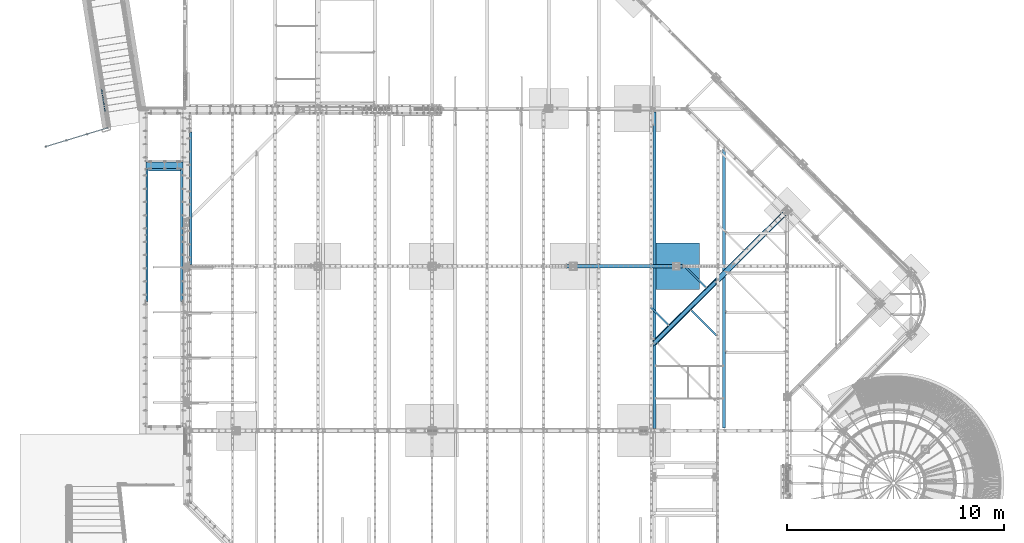
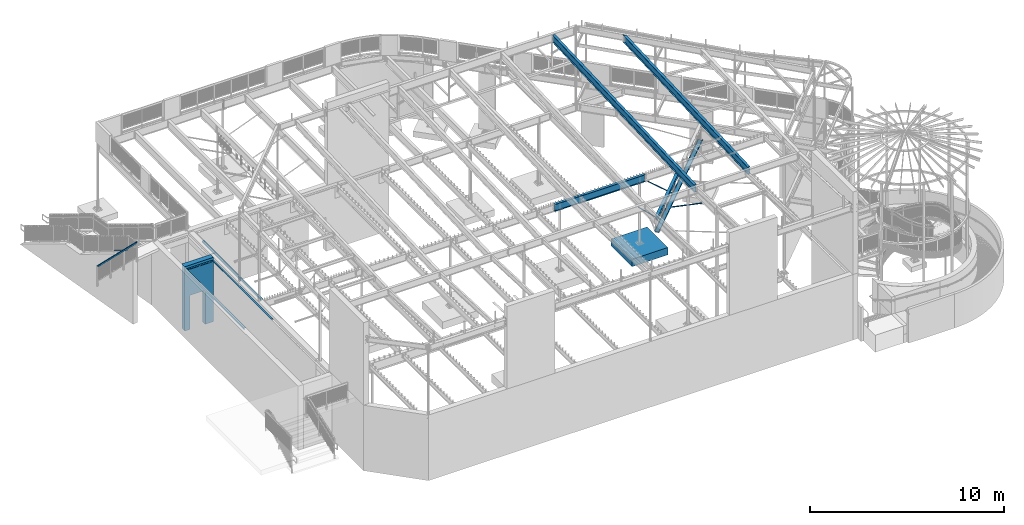
# One storey, part 318 of 975: 15 beams, 1 member.
"""IFC2X3 building model written with IfcOpenShell, lengths in millimetres."""

from ifc_helpers import new_model, si_unit, frame, origin_with_axes, place, context, subcontext, project, spatial, faceted_brep, material, type_object, element, save


model = new_model("IFC2X3")

# Units and contexts
model_context = context("Model", 3, precision=1e-05, world=origin_with_axes())
body_context = subcontext(model_context, "Body", "Model", "MODEL_VIEW")
ifc_project = project(units=[si_unit("LENGTHUNIT", "METRE", prefix="MILLI"), si_unit("AREAUNIT", "SQUARE_METRE"), si_unit("VOLUMEUNIT", "CUBIC_METRE"), si_unit("MASSUNIT", "GRAM", prefix="KILO"), si_unit("TIMEUNIT", "SECOND"), si_unit("PLANEANGLEUNIT", "RADIAN"), si_unit("SOLIDANGLEUNIT", "STERADIAN"), si_unit("THERMODYNAMICTEMPERATUREUNIT", "DEGREE_CELSIUS"), si_unit("LUMINOUSINTENSITYUNIT", "LUMEN")], contexts=[model_context])

# Site, building, storey
site_placement = place(None, origin_with_axes())
site = spatial("IfcSite", under=ifc_project, at=site_placement, CompositionType="ELEMENT")
building_placement = place(site_placement, origin_with_axes())
building = spatial("IfcBuilding", under=site, at=building_placement, Name="Undefined", CompositionType="ELEMENT")
storey_placement = place(building_placement, origin_with_axes())
storey = spatial("IfcBuildingStorey", under=building, at=storey_placement, Name="Undefined", CompositionType="ELEMENT", Elevation=0.0)

# Beams
ifc_material_1 = material(Name="STEEL/A36")
beam_type_1 = type_object("IfcBeamType", Name="L3X3X3/16", PredefinedType="NOTDEFINED")
beam_1_placement = place(storey_placement, frame((23532.3947969943, 11528.9190808216, 3502.75524173699), z_axis=(-0.709247305908776, -0.704959757050815, -4.93100742460229e-11), x_axis=(0.632701534936731, -0.636549610936345, -0.441014013955898)))
element("IfcBeam", 1, at=beam_1_placement, inside=storey, type_object=beam_type_1, material=ifc_material_1, Name="ANGLE", ObjectType="L3X3X3/16", context=body_context, shape_type="Brep", body=[
    faceted_brep([(1300.11028612074, -38.0999926474587, -33.3375000002998), (1300.11028612073, -38.0999919468331, -38.1000000003223), (1300.11028576719, 33.3375071467353, -38.1000000003878), (1300.11028575761, 33.3375071517066, -33.3375000008564), (1328.20676165132, -23.8411616900694, -38.1000000004606), (1328.20676259087, -23.8411612278051, -33.337500000016), (1332.4811051317, -21.7408313065953, 38.1000000000422), (1328.20676258711, -23.8411612207919, 38.1000000000276), (1332.48110667282, -21.7408305587751, -38.1000000000058), (29.8255381832114, -38.0999998359339, -33.337500000096), (29.8255381837498, -38.0999998359357, -38.1000000001004), (1255.61719203559, -38.0999930930348, -38.1000000009262), (1255.61719203553, -38.0999930930348, -33.3375000009219), (29.8255378065924, 38.1000001640541, -38.0999999999949), (29.8255378296262, 33.3375001640552, -33.3374999999978), (29.8255378215326, 33.3375001640679, 38.1000000000458), (29.8255377979613, 38.1000001640668, 38.1000000000495), (1303.07649200474, 38.1000071680346, 38.0999999991909), (1303.07649200582, 38.1000071680219, -38.1000000008607), (1300.1102857566, 33.3375071517194, 38.0999999991873)], [[[0, 1, 2, 3]], [[3, 2, 4, 5]], [[6, 7, 5, 4, 8]], [[9, 10, 11, 12]], [[13, 10, 9, 14, 15, 16]], [[13, 16, 17, 18]], [[18, 17, 6, 8]], [[2, 1, 11, 10, 13, 18, 8, 4]], [[12, 11, 1, 0]], [[14, 9, 12, 0, 3]], [[15, 14, 3, 19]], [[19, 3, 5, 7]], [[17, 16, 15, 19, 7, 6]]]),
])
beam_2_placement = place(storey_placement, frame((25439.2732581106, 11339.9529433271, 2870.2), z_axis=(-0.709199630836852, -0.705007718837796, 0.0), x_axis=(0.0, 0.0, 1.0)))
element("IfcBeam", 2, at=beam_2_placement, inside=storey, type_object=beam_type_1, material=ifc_material_1, Name="ANGLE", ObjectType="L3X3X3/16", context=body_context, shape_type="Brep", body=[
    faceted_brep([(25.4024092950699, 33.3375000220076, 38.0996831838311), (25.4024106305014, 38.1000000220156, 38.0996831838165), (25.4024106075244, 38.1000000220774, -38.1003168220304), (25.4024092720929, 33.3373553605707, -38.1003168220159), (25.402409273529, 33.3375000220658, -33.337816821655), (88.6495798217943, 33.3374797291181, -33.3386056411655), (88.6493538730001, 33.3374980933804, -38.1011056385905), (20.9337944619647, 10.5729718175626, -38.1002610894247), (20.9336505701117, 10.5730674953247, -33.3377610872667), (92.0727332259908, 38.1000000797758, -38.1011483350085), (92.0772756973574, 38.1000000797139, 38.0988516141842), (109.689939138608, -14.2966740807897, 38.096898254993), (109.687479406867, -14.2921842647538, -38.1031015729495), (651.166944553913, -1624.99578907391, 37.9845146471816), (651.164484834565, -1624.99129929474, -38.2154851807682), (37.298686389729, -38.0999999677424, -38.1004651925723), (88.6538977700911, 33.3375000767483, 38.0988943105876), (105.173392271, -15.8100404521865, -33.340545282048), (105.175698269507, -15.8142496547207, 38.0969545566513), (37.2989702941895, -38.0999999677442, -33.3379651957475), (37.4597792344907, -38.5736740610846, -33.3397007571657), (36.7987457864328, -36.61339332444, -33.3379589569413), (37.4596255012571, -38.5733934475829, -38.1022007464089), (578.936630933475, -1649.27250849101, -38.2145843542203), (578.936784665934, -1649.27278910221, -33.4520843649771), (646.650397698207, -1626.50915548071, -33.4529288898593), (646.652703685095, -1626.51336464868, 37.9845709488436)], [[[0, 1, 2, 3, 4]], [[5, 6, 7, 8]], [[4, 3, 6, 5]], [[9, 10, 11, 12]], [[12, 11, 13, 14]], [[15, 7, 6]], [[16, 5, 17, 18]], [[5, 19, 20, 17]], [[21, 19, 5, 8]], [[15, 19, 21, 8, 7]], [[20, 19, 15, 22, 23, 24]], [[17, 20, 24, 25]], [[18, 17, 25, 26]], [[11, 18, 26, 13]], [[25, 24, 23, 14, 13, 26]], [[22, 12, 14, 23]], [[15, 6, 9, 12, 22]], [[2, 9, 6, 3]], [[10, 9, 2, 1]], [[16, 18, 11, 10, 1, 0]], [[5, 16, 0, 4]]]),
])
beam_3_placement = place(storey_placement, frame((25135.3295319196, 13375.0116337592, 3450.62546657707), z_axis=(-0.709179074487965, -0.705028396809939, -8.76857484399806e-11), x_axis=(0.657370205901574, -0.661240307900995, -0.361421730945886)))
element("IfcBeam", 3, at=beam_3_placement, inside=storey, type_object=beam_type_1, material=ifc_material_1, Name="ANGLE", ObjectType="L3X3X3/16", context=body_context, shape_type="Brep", body=[
    faceted_brep([(1446.22221908493, -38.1000412902176, -33.3375000004489), (1446.22234837766, -38.1000092563336, -38.1000000004569), (1446.22234884808, 33.3375413504145, -38.1000000005261), (1446.22221952836, 33.337491228931, -33.3375000006599), (1469.14322783126, -25.7884124715474, -38.1000000005297), (1469.14115987072, -25.7892140619915, -33.3375000003944), (1473.55211840428, -24.0794174486964, 38.0999990750715), (1469.14115986524, -25.7892140483646, 38.0999999996202), (1473.58172572751, -24.0679409512677, -38.1000000003878), (40.491462140827, -38.1000002455685, -33.3375000000196), (40.4915914333369, -38.1000002455667, -38.100000000024), (1397.29652750821, -38.1000084743628, -38.1000000006425), (1397.29652750818, -38.1000084743655, -33.3375000006417), (40.4915919351606, 38.0999997544568, -38.1000000000204), (40.491462611285, 33.3374997544524, -33.3375000000233), (40.4895232236322, 33.3374997544306, 38.0999999999876), (40.489523254997, 38.0999997544313, 38.0999999999913), (1449.4839323293, 38.0999912091138, 38.0999999993437), (1449.48393232973, 38.099991209152, -38.1000000006643), (1446.22221952795, 33.3374912288946, 38.0999999993473)], [[[0, 1, 2, 3]], [[3, 2, 4, 5]], [[6, 7, 5, 4, 8]], [[9, 10, 11, 12]], [[13, 10, 9, 14, 15, 16]], [[13, 16, 17, 18]], [[18, 17, 6, 8]], [[2, 1, 11, 10, 13, 18, 8, 4]], [[12, 11, 1, 0]], [[14, 9, 12, 0, 3]], [[15, 14, 3, 19]], [[19, 3, 5, 7]], [[17, 16, 15, 19, 7, 6]]]),
])
beam_type_2 = type_object("IfcBeamType", Name="C10X15.3", PredefinedType="NOTDEFINED")
beam_4_placement = place(storey_placement, frame((23709.1622039582, 9853.15276556714, 2928.9375), z_axis=(-0.705001493913394, 0.709205818912876, 0.0), x_axis=(0.709205818912877, 0.705001493913393, 0.0)))
element("IfcBeam", 4, at=beam_4_placement, inside=storey, type_object=beam_type_2, material=ifc_material_1, Name="BEAM", ObjectType="C10X15.3", context=body_context, shape_type="Brep", body=[
    faceted_brep([(-1.70985003933311e-10, 33.3375000000001, -126.999999999975), (1.78260961547494e-10, 33.3375000000001, 126.999999999975), (8561.77582131003, 33.3375000000001, 127.000000010328), (8561.77582130969, 33.3375000000001, -126.999999989615), (1.78260961547494e-10, -33.3375000000001, 126.999999999975), (8561.77582131003, -33.3375000000001, 127.000000010328), (1.70985003933311e-10, -33.3375000000001, 121.441527499974), (8561.77582131002, -33.3375000000001, 121.441527510331), (1.52795109897852e-10, 26.9875000000002, 111.391382499978), (8561.77582131001, 26.9875000000002, 111.391382510332), (-1.4915713109076e-10, 26.9875000000002, -111.391382499976), (8561.7758213097, 26.9875000000002, -111.391382489623), (-1.63709046319127e-10, -33.3375000000001, -121.44152749997), (8561.77582130969, -33.3375000000001, -121.44152748962), (-1.70985003933311e-10, -33.3375000000001, -126.999999999975), (8561.77582130969, -33.3375000000001, -126.999999989615)], [[[0, 1, 2, 3]], [[1, 4, 5, 2]], [[4, 6, 7, 5]], [[6, 8, 9, 7]], [[8, 10, 11, 9]], [[10, 12, 13, 11]], [[12, 14, 15, 13]], [[14, 0, 3, 15]], [[5, 7, 9, 11, 13, 15, 3, 2]], [[14, 12, 10, 8, 6, 4, 1, 0]]]),
])

# Member
ifc_material_2 = material()
member_type = type_object("IfcMemberType", Name="HSS2X2X.188_TUBES", PredefinedType="NOTDEFINED")
member_placement = place(storey_placement, frame((-1566.59606604863, 20495.0382177433, 4156.06369803968), z_axis=(-0.987688340611262, -0.156434464938429, 0.0), x_axis=(-0.136949714005939, 0.864666463037498, -0.48331840802096)))
element("IfcMember", 5, at=member_placement, inside=storey, type_object=member_type, material=ifc_material_2, Name="HANDRAIL", ObjectType="HSS2X2X.188_TUBES", context=body_context, shape_type="Brep", body=[
    faceted_brep([(11.8642640238013, 20.6375000000335, -20.6374999999921), (1.22733809156853, -20.6375000000007, -20.6374999999969), (1238.07006098514, -20.6374999993386, -20.6374999995667), (1260.8573009263, 20.6375000007029, -20.6374999995567), (1.22733724917089, -20.6375000000298, 20.6374999999966), (1238.07006099668, -20.6374999993677, 20.6375000004277), (11.8642631814091, 20.6375000000062, 20.6375000000016), (1260.85730093784, 20.6375000006756, 20.6375000004366), (13.0916017285726, 25.4000000000415, -25.399999999991), (13.091600691776, 25.4000000000069, 25.4000000000019), (1263.48659785546, 25.4000000006763, 25.4000000004369), (1263.48659784126, 25.4000000007109, -25.3999999995553), (0.0, -25.399999999976, 25.4000000000378), (1235.44076408172, -25.3999999993739, 25.4000000004262), (0.0, -25.400000000016, -25.4000000000196), (1235.44076406752, -25.399999999343, -25.3999999995665)], [[[0, 1, 2, 3]], [[1, 4, 5, 2]], [[4, 6, 7, 5]], [[6, 0, 3, 7]], [[8, 9, 10, 11]], [[9, 12, 13, 10]], [[12, 14, 15, 13]], [[14, 8, 11, 15]], [[13, 15, 11, 10], [5, 7, 3, 2]], [[14, 12, 9, 8], [6, 4, 1, 0]]]),
])

# Beams
beam_type_3 = type_object("IfcBeamType", Name="HSS2X4X.188_TUBES", PredefinedType="NOTDEFINED")
beam_5_placement = place(storey_placement, frame((-4319.00190015015, 18892.4885227824, 5054.60000245407), z_axis=(0.0, 0.0, 1.0), x_axis=(0.957133194582284, 0.289648144873591, -7.00000007209117e-09)))
element("IfcBeam", 6, at=beam_5_placement, inside=storey, type_object=beam_type_3, material=ifc_material_2, Name="HANDRAIL", ObjectType="HSS2X4X.188_TUBES", context=body_context, shape_type="Brep", body=[
    faceted_brep([(48.4191015633237, 20.6374999999098, -46.0375000000195), (48.4191015390466, -20.6375000000298, -46.0375000000176), (2974.18090202078, -20.6375000009939, -46.0375000011309), (2974.1809020171, 20.6374999989457, -46.0375000011336), (2.38089921895971, -20.6374999999134, 46.0374999999995), (3020.21910287946, -20.6375000009139, 46.0374999988517), (2.38089924323685, 20.6375000000226, 46.0374999999976), (3020.21910287578, 20.6374999990294, 46.037499998848), (50.8003878930272, 25.399999999896, -50.8000000000211), (-0.000387080863220035, 25.4000000000196, 50.7999999999984), (3022.60038912666, 25.3999999990228, 50.7999999988479), (2971.79961576536, 25.3999999989319, -50.8000000011325), (-0.000387110743758967, -25.3999999999032, 50.8000000000011), (3022.6003891312, -25.4000000009, 50.7999999988506), (50.8003878631466, -25.4000000000269, -50.8000000000184), (2971.7996157699, -25.400000000991, -50.8000000011298)], [[[0, 1, 2, 3]], [[1, 4, 5, 2]], [[4, 6, 7, 5]], [[6, 0, 3, 7]], [[8, 9, 10, 11]], [[9, 12, 13, 10]], [[12, 14, 15, 13]], [[14, 8, 11, 15]], [[13, 15, 11, 10], [5, 7, 3, 2]], [[14, 12, 9, 8], [6, 4, 1, 0]]]),
])
ifc_material_3 = material(Name="STEEL/A992")
beam_type_4 = type_object("IfcBeamType", Name="W8X24", PredefinedType="NOTDEFINED")
beam_6_placement = place(storey_placement, frame((23571.2, 9715.93775265419, 3836.9875), z_axis=(0.0, 0.0, 1.0), x_axis=(0.709199573009271, 0.70500777700921, 0.0)))
element("IfcBeam", 7, at=beam_6_placement, inside=storey, type_object=beam_type_4, material=ifc_material_3, Name="BEAM", ObjectType="W8X24", context=body_context, shape_type="Brep", body=[
    faceted_brep([(194.653800207496, 82.5500000002939, -100.0125), (194.653800207496, 82.5500000002939, -90.4875000000002), (4303.08830986538, 82.5500000037828, -90.4875000000002), (4303.08830986538, 82.5500000037828, -100.0125), (115.747954195067, 3.17500000010114, -90.4875000000002), (4224.18246385294, 3.1750000035936, -90.4875000000002), (115.747954195067, 3.17500000010114, 90.4875000000002), (4224.18246385294, 3.1750000035936, 90.4875000000002), (194.653800207496, 82.5500000002939, 90.4875000000002), (4303.08830986538, 82.5500000037828, 90.4875000000002), (194.653800207496, 82.5500000002939, 100.0125), (4303.08830986538, 82.5500000037828, 100.0125), (30.5296405016379, -82.550000000103, 100.0125), (4138.96415015952, -82.5499999966141, 100.0125), (30.5296405016379, -82.550000000103, 90.4875000000002), (4138.96415015952, -82.5499999966141, 90.4875000000002), (109.43548651407, -3.17499999991196, 90.4875000000002), (4217.86999617195, -3.17499999642314, 90.4875000000002), (109.43548651407, -3.17499999991196, -90.4875000000002), (4217.86999617195, -3.17499999642314, -90.4875000000002), (30.5296405016379, -82.550000000103, -90.4875000000002), (4138.96415015952, -82.5499999966141, -90.4875000000002), (30.5296405016379, -82.550000000103, -100.0125), (4138.96415015952, -82.5499999966141, -100.0125)], [[[0, 1, 2, 3]], [[1, 4, 5, 2]], [[4, 6, 7, 5]], [[6, 8, 9, 7]], [[8, 10, 11, 9]], [[10, 12, 13, 11]], [[12, 14, 15, 13]], [[14, 16, 17, 15]], [[16, 18, 19, 17]], [[18, 20, 21, 19]], [[20, 22, 23, 21]], [[22, 0, 3, 23]], [[5, 7, 9, 11, 13, 15, 17, 19, 21, 23, 3, 2]], [[22, 20, 18, 16, 14, 12, 10, 8, 6, 4, 1, 0]]]),
])
ifc_material_4 = material(Name="CONCRETE/5000")
beam_type_5 = type_object("IfcBeamType", PredefinedType="NOTDEFINED")
beam_7_placement = place(storey_placement, frame((304.8000057404, 18030.825, 2019.3), z_axis=(0.0, 0.0, 1.0), x_axis=(1.0, 0.0, 0.0)))
element("IfcBeam", 8, at=beam_7_placement, inside=storey, type_object=beam_type_5, material=ifc_material_4, Name="WALL", context=body_context, shape_type="Brep", body=[
    faceted_brep([(304.799822998043, -152.400000000001, -2019.3), (304.799822998043, 152.400000000001, -2019.3), (304.800006487652, 152.400000000001, 114.300097656242), (304.800006487652, -152.400000000001, 114.300097656242), (1219.20003090171, -152.400000000001, 114.30001901784), (1219.20003090171, 152.400000000001, 114.30001901784), (1219.20003051758, 152.400000000001, -2019.3), (1219.20003051758, -152.400000000001, -2019.3), (0.0, -152.4, -2019.3), (0.0, -152.4, 2019.3), (0.0, 152.4, 2019.3), (0.0, 152.4, -2019.3), (1711.3249698375, -152.4, 2019.3), (1711.3249698375, 152.4, 2019.3), (1711.3249698375, -152.4, -2019.3), (1711.3249698375, 152.4, -2019.3)], [[[0, 1, 2, 3]], [[4, 5, 6, 7]], [[3, 2, 5, 4]], [[8, 9, 10, 11]], [[10, 9, 12, 13]], [[12, 14, 15, 13]], [[15, 14, 7, 6]], [[1, 11, 10, 13, 15, 6, 5, 2]], [[8, 11, 1, 0]], [[14, 12, 9, 8, 0, 3, 4, 7]]]),
])
beam_type_6 = type_object("IfcBeamType", Name="L4X4X5/16", PredefinedType="NOTDEFINED")
for number, where, z_axis, x_axis, name in (
    (9, (355.599989643705, 11769.7250003556, 3835.4), (1.0, 0.0, 0.0), (0.0, 1.0, 0.0), "LEDGER_ANGLE"),
    (10, (1965.3250542864, 17865.7250003556, 3835.4), (-0.999999999999998, 6.90000001668524e-08, 0.0), (0.0, -1.0, 0.0), "LEDGER_ANGLE"),
    (11, (2371.72501101716, 13481.0499970009, 3886.2), (1.0, 0.0, 0.0), (0.0, 1.0, 0.0), "LEDGER_ANGLE"),
):
    element("IfcBeam", number, at=place(storey_placement, frame(where, z_axis=z_axis, x_axis=x_axis)), inside=storey, type_object=beam_type_6, material=ifc_material_1, Name=name, ObjectType="L4X4X5/16", context=body_context, shape_type="Brep", body=[
        faceted_brep([(-1.90993887372315e-11, 50.8000000000002, -50.8), (2.00088834390044e-11, 50.8000000000002, 50.8), (6095.99999999997, 50.8000000000002, 50.8000000001048), (6096.00000000003, 50.8000000000002, -50.7999999998952), (2.00088834390044e-11, 42.8625000000002, 50.8), (6095.99999999997, 42.8625000000002, 50.8000000001048), (-1.63709046319127e-11, 42.8625000000002, -42.8625), (6096.00000000003, 42.8625000000002, -42.8624999998952), (-1.63709046319127e-11, -50.8000000000002, -42.8625), (6096.00000000003, -50.8000000000002, -42.8624999998952), (-1.90993887372315e-11, -50.8000000000002, -50.8), (6096.00000000003, -50.8000000000002, -50.7999999998952)], [[[0, 1, 2, 3]], [[1, 4, 5, 2]], [[4, 6, 7, 5]], [[6, 8, 9, 7]], [[8, 10, 11, 9]], [[10, 0, 3, 11]], [[5, 7, 9, 11, 3, 2]], [[10, 8, 6, 4, 1, 0]]]),
    ])
beam_8_placement = place(storey_placement, frame((419.099990636183, 17827.625, 3835.4), z_axis=(0.0, -1.0, 0.0), x_axis=(1.0, 0.0, 0.0)))
element("IfcBeam", 12, at=beam_8_placement, inside=storey, type_object=beam_type_6, material=ifc_material_1, Name="LEDGER_ANGLE", ObjectType="L4X4X5/16", context=body_context, shape_type="Brep", body=[
    faceted_brep([(-1.90993887372315e-11, 50.8000000000002, -50.8), (2.00088834390044e-11, 50.8000000000002, 50.8), (1482.7250193691, 50.8000000000002, 50.8000000000002), (1482.7250193691, 50.8000000000002, -50.8000000000002), (2.00088834390044e-11, 42.8625000000002, 50.8), (1482.7250193691, 42.8625000000002, 50.8000000000002), (-1.63709046319127e-11, 42.8625000000002, -42.8625), (1482.7250193691, 42.8625000000002, -42.8625000000002), (-1.63709046319127e-11, -50.8000000000002, -42.8625), (1482.7250193691, -50.8000000000002, -42.8625000000002), (-1.90993887372315e-11, -50.8000000000002, -50.8), (1482.7250193691, -50.8000000000002, -50.8000000000002)], [[[0, 1, 2, 3]], [[1, 4, 5, 2]], [[4, 6, 7, 5]], [[6, 8, 9, 7]], [[8, 10, 11, 9]], [[10, 0, 3, 11]], [[5, 7, 9, 11, 3, 2]], [[10, 8, 6, 4, 1, 0]]]),
])
beam_type_7 = type_object("IfcBeamType", Name="W18X40", PredefinedType="NOTDEFINED")
beam_9_placement = place(storey_placement, frame((26920.825, 5829.20043900914, 8002.78325531019), z_axis=(0.0, -0.0415194719974033, 0.999137694937518), x_axis=(0.0, 0.999137694937518, 0.0415194719974035)))
element("IfcBeam", 13, at=beam_9_placement, inside=storey, type_object=beam_type_7, material=ifc_material_3, Name="BEAM", ObjectType="W18X40", context=body_context, shape_type="Brep", body=[
    faceted_brep([(8.66859005903461, -3.96875, -195.262500000458), (8.66859005903461, 3.96875, -195.262500000458), (83.5492093047524, 3.96875, -195.262500000475), (83.5492093047524, -3.96875, -195.262500000475), (88.409288822796, 3.96875, -196.229229923065), (88.409288822796, -3.96875, -196.229229923065), (92.5294652909479, 3.96875, -198.982243823543), (92.5294652909479, -3.96875, -198.982243823543), (95.2824791914227, 3.96875, -203.102420291695), (95.2824791914227, -3.96875, -203.102420291695), (96.2492091140093, -3.96875, -207.962499809741), (96.2492091140093, 3.96875, -207.962499809741), (96.2492091140075, 3.96875, -214.312499999999), (96.2492091140075, 76.2000000000007, -214.312499999999), (96.2492091140066, 76.2000000000007, -227.012499999997), (96.2492091140057, -76.2000000000007, -227.012499809801), (96.2492091140075, -76.2000000000007, -214.312499999999), (96.2492091140075, -3.96875, -214.312499999999), (12850.336447893, -76.2000000000007, 214.312499996935), (12850.8642002837, -76.2000000000007, 227.012499996932), (115.299209114119, -76.2000000000007, 227.012499999946), (115.299209114116, -76.2000000000007, 214.312499999949), (13003.4503771673, 76.2000000000007, 227.012499996896), (115.299209114119, 76.2000000000007, 227.012499999946), (13002.9226247767, 76.2000000000007, 214.312499996899), (115.299209114116, 76.2000000000007, 214.312499999949), (12930.6031346912, 3.96875, 214.312499996914), (115.299209114116, 3.96875, 214.312499999949), (102.599209304848, -3.96875, 195.262499999887), (102.599209304848, 3.96875, 195.262499999887), (24.8969756799124, 3.96875, 195.26249999991), (24.8969756799124, -3.96875, 195.26249999991), (107.459288822893, -3.96875, 196.229229922476), (107.459288822893, 3.96875, 196.229229922476), (111.579465291045, -3.96875, 198.982243822954), (111.579465291045, 3.96875, 198.982243822954), (114.332479191524, -3.96875, 203.10242029111), (114.332479191524, 3.96875, 203.10242029111), (115.299209114113, -3.96875, 207.962499809158), (115.299209114113, 3.96875, 207.962499809158), (115.299209114116, -3.96875, 214.312499999949), (12922.6559379785, -3.96875, 214.312499996917), (12912.7914915072, 3.96875, -214.312500003033), (12904.8442947945, -3.96875, -214.31250000303), (12832.524804709, -76.2000000000007, -214.312500003016), (12831.9970523184, -76.2000000000007, -227.012500003012), (12984.5832292021, 76.2000000000007, -227.012500003048), (12985.1109815927, 76.2000000000007, -214.31250000305)], [[[0, 1, 2, 3]], [[3, 2, 4, 5]], [[5, 4, 6, 7]], [[7, 6, 8, 9]], [[10, 11, 12, 13, 14, 15, 16, 17]], [[9, 8, 11, 10]], [[18, 19, 20, 21]], [[19, 22, 23, 20]], [[22, 24, 25, 23]], [[24, 26, 27, 25]], [[28, 29, 30, 31]], [[32, 33, 29, 28]], [[34, 35, 33, 32]], [[36, 37, 35, 34]], [[38, 39, 37, 36]], [[20, 23, 25, 27, 39, 38, 40, 21]], [[41, 18, 21, 40]], [[42, 26, 24, 22, 19, 18, 41, 43, 44, 45, 46, 47]], [[44, 43, 17, 16]], [[45, 44, 16, 15]], [[46, 45, 15, 14]], [[47, 46, 14, 13]], [[42, 47, 13, 12]], [[6, 4, 2, 1, 30, 29, 33, 35, 37, 39, 27, 26, 42, 12, 11, 8]], [[31, 30, 1, 0]], [[43, 41, 40, 38, 36, 34, 32, 28, 31, 0, 3, 5, 7, 9, 10, 17]]]),
])
beam_10_placement = place(storey_placement, frame((23723.6, 5829.11637334778, 8002.77977754138), z_axis=(0.0, -0.0411491589862163, 0.999153014665285), x_axis=(0.0, 0.999153014665285, 0.0411491589862177)))
element("IfcBeam", 14, at=beam_10_placement, inside=storey, type_object=beam_type_7, material=ifc_material_3, Name="BEAM", ObjectType="W18X40", context=body_context, shape_type="Brep", body=[
    faceted_brep([(14657.5609744888, -76.2000000000007, -214.312499994021), (14657.5609744888, -76.2000000000007, -227.012499992623), (14657.5609744888, 76.2000000000007, -227.012499994023), (14657.5609744888, 76.2000000000007, -214.312499994021), (14657.5609744888, 3.96875, -214.312499994021), (14657.5609744888, -3.96875, -214.312499994021), (14658.5277044114, 3.96865543364765, -209.452420103776), (14658.5277044114, -3.96875, -209.452420103776), (14661.2807183119, 3.96865541555962, -205.332243635633), (14661.2807183119, -3.96875, -205.332243635633), (14665.40089478, 3.9686554016771, -202.579229735162), (14665.40089478, -3.96875, -202.579229735162), (14670.2609742981, 3.9686553941101, -201.612499812572), (14670.2609742981, -3.96875, -201.612499812572), (14765.5109744548, -3.96875, -201.612499812583), (14765.5109744548, 3.96875, -201.612499812583), (109.117370300622, 3.96875, 214.312500000065), (109.117370300622, 76.2000000000007, 214.312500000065), (14676.6109744899, 76.2000000000007, 214.312500006024), (14676.6109744899, 3.96875, 214.312500006024), (71.0173703004075, -3.96875, -207.962499809312), (71.0173703004075, 3.96875, -207.962499809312), (71.0173703004093, 3.96875, -214.312499999988), (71.0173703004093, 76.2000000000007, -214.312499999988), (71.0173703004139, 76.2000000000007, -227.012499999989), (71.0173703004148, -76.2000000000007, -227.012499809476), (71.0173703004093, -76.2000000000007, -214.312499999988), (71.0173703004093, -3.96875, -214.312499999988), (70.0506403778163, -3.96875, -203.102420291266), (70.0506403778163, 3.96875, -203.102420291266), (67.2976264773361, -3.96875, -198.982243823111), (67.2976264773361, 3.96875, -198.982243823111), (63.1774500091806, -3.96875, -196.229229922636), (63.1774500091806, 3.96875, -196.229229922636), (58.3173704911333, -3.96875, -195.262500000049), (58.3173704911333, 3.96875, -195.262500000049), (8.8249636104365, -3.96875, -195.262500000069), (8.8249636104365, 3.96875, -195.262500000069), (24.9083613255289, -3.96875, 195.262500000009), (24.9083613255289, 3.96875, 195.262500000009), (96.4173704913837, -3.96875, 195.262500000037), (96.4173704913837, 3.96875, 195.262500000037), (101.277450009429, -3.96875, 196.229229922624), (101.277450009429, 3.96875, 196.229229922624), (105.397626477584, -3.96875, 198.9822438231), (105.397626477584, 3.96875, 198.9822438231), (108.15064037806, -3.96875, 203.102420291253), (108.15064037806, 3.96875, 203.102420291253), (109.117370300646, -3.96875, 207.962499809298), (109.117370300646, 3.96875, 207.962499809298), (109.117370300628, -76.2000000000007, 227.012500000065), (109.117370300628, 76.2000000000007, 227.012500000065), (109.117370300622, -3.96875, 214.312500000065), (109.117370300622, -76.2000000000007, 214.312500000065), (14676.6109744899, -3.96875, 214.312500006024), (14676.6109744899, -76.2000000000007, 214.312500006024), (14676.6109744899, -76.2000000000007, 227.012500006025), (14676.6109744899, 76.2000000000007, 227.012500006025), (14677.5777044125, -3.96875, 209.452420478925), (14677.5777044125, 3.96826458708529, 209.452420478925), (14680.330718313, -3.96875, 205.332244010762), (14680.330718313, 3.96826481508469, 205.332244010762), (14684.4508947812, -3.96875, 202.579230110274), (14684.4508947812, 3.96826496742869, 202.579230110274), (14689.3109742992, -3.96875, 201.612500187682), (14689.3109742992, 3.96826502092517, 201.612500187682), (14765.5109744548, -3.96875, 201.612500187783), (14765.5109744548, 3.96875, 201.612500187783)], [[[0, 1, 2, 3, 4, 5]], [[5, 4, 6, 7]], [[7, 6, 8, 9]], [[9, 8, 10, 11]], [[11, 10, 12, 13]], [[14, 13, 12, 15]], [[16, 17, 18, 19]], [[20, 21, 22, 23, 24, 25, 26, 27]], [[28, 29, 21, 20]], [[30, 31, 29, 28]], [[32, 33, 31, 30]], [[34, 35, 33, 32]], [[36, 37, 35, 34]], [[38, 39, 37, 36]], [[40, 41, 39, 38]], [[42, 43, 41, 40]], [[44, 45, 43, 42]], [[46, 47, 45, 44]], [[48, 49, 47, 46]], [[50, 51, 17, 16, 49, 48, 52, 53]], [[53, 52, 54, 55]], [[50, 53, 55, 56]], [[51, 50, 56, 57]], [[17, 51, 57, 18]], [[56, 55, 54, 19, 18, 57]], [[58, 59, 19, 54]], [[60, 61, 59, 58]], [[62, 63, 61, 60]], [[64, 65, 63, 62]], [[66, 67, 65, 64]], [[67, 66, 14, 15]], [[10, 8, 6, 4, 22, 21, 29, 31, 33, 35, 37, 39, 41, 43, 45, 47, 49, 16, 19, 59, 61, 63, 65, 67, 15, 12]], [[23, 22, 4, 3]], [[24, 23, 3, 2]], [[25, 24, 2, 1]], [[26, 25, 1, 0]], [[27, 26, 0, 5]], [[66, 64, 62, 60, 58, 54, 52, 48, 46, 44, 42, 40, 38, 36, 34, 32, 30, 28, 20, 27, 5, 7, 9, 11, 13, 14]]]),
])
beam_type_8 = type_object("IfcBeamType", Name="W18X35", PredefinedType="NOTDEFINED")
beam_11_placement = place(storey_placement, frame((19667.5375, 13392.15, 3711.575), z_axis=(0.0, 0.0, 1.0), x_axis=(1.0, 0.0, 0.0)))
element("IfcBeam", 15, at=beam_11_placement, inside=storey, type_object=beam_type_8, material=ifc_material_3, Name="BEAM", ObjectType="W18X35", context=body_context, shape_type="Brep", body=[
    faceted_brep([(14.287031462678, -76.1999999999998, 225.425), (14.287031462678, 76.1999999999998, 225.425), (3.17496870515606, 76.1999999999998, 214.312499999999), (3.17496870515606, 3.96875, 214.312499999999), (2.77798382235414, 3.96875, 213.915499496458), (2.77798382235414, -3.96875, 213.915499496458), (3.17496870515606, -3.96875, 214.312499999999), (3.17496870515606, -76.1999999999998, 214.312499999999), (22.2250007629409, -3.96875, 213.915499496458), (22.2250007629409, 3.96875, 213.915499496458), (40.7122683048001, 3.96875, 203.575605287907), (40.7122683048001, -3.96875, 203.575605287907), (44.8249534620081, 3.96875, 198.997422721183), (44.8249534620081, -3.96875, 198.997422721183), (45.2798117862694, 3.96875, 192.860074863892), (45.2798117862694, -3.96875, 192.860074863892), (41.8869600345242, 3.96875, 187.725633140859), (41.8869600345242, -3.96875, 187.725633140859), (36.0627638298283, 3.96875, 185.737499999999), (36.0627638298283, -3.96875, 185.737499999999), (6.34999999999854, 3.96875, 185.737499999999), (6.34999999999854, -3.96875, 185.737499999999), (6.34999999999854, 3.96875, -185.7375), (6.34999999999854, -3.96875, -185.7375), (47.9687625480874, 3.96875, -185.7375), (47.9687625480874, -3.96875, -185.7375), (53.7929587527833, 3.96875, -187.72563314086), (53.7929587527833, -3.96875, -187.72563314086), (57.1858105045285, 3.96875, -192.860074863893), (57.1858105045285, -3.96875, -192.860074863893), (56.7309521802672, 3.96875, -198.997422721185), (56.7309521802672, -3.96875, -198.997422721185), (52.6182670230592, 3.96875, -203.575605287907), (52.6182670230592, -3.96875, -203.575605287907), (34.1309994812, 3.96875, -213.91549949646), (34.1309994812, -3.96875, -213.91549949646), (14.6840158801024, 3.96875, -213.91549949646), (14.6840158801024, -3.96875, -213.91549949646), (5354.63796900269, 3.96875, -214.3125), (5354.63796900269, 76.2000000000007, -214.3125), (14.2870309973041, 76.1999999999998, -214.3125), (14.2870309973041, 3.96875, -214.3125), (5365.75003176022, 76.2000000000007, -225.425), (3.17496823977854, 76.1999999999998, -225.425), (5365.75003176022, -76.2000000000007, -225.425), (3.17496823977854, -76.1999999999998, -225.425), (5354.63796900269, -76.2000000000007, -214.3125), (14.2870309973041, -76.1999999999998, -214.3125), (14.2870309973041, -3.96875, -214.3125), (5354.63796900269, -3.96875, -214.3125), (5354.24098411989, 3.96875, -213.91549949646), (5354.24098411989, -3.96875, -213.91549949646), (5334.7939967041, 3.96875, -213.91549949646), (5334.7939967041, -3.96875, -213.91549949646), (5316.30673029388, 3.96875, -203.575605137925), (5316.30673029388, -3.96875, -203.575605137925), (5312.19404531447, 3.96875, -198.997422509199), (5312.19404531447, -3.96875, -198.997422509199), (5311.73918711932, 3.96875, -192.860074715233), (5311.73918711932, -3.96875, -192.860074715233), (5315.1320388931, 3.96875, -187.725633093891), (5315.1320388931, -3.96875, -187.725633093891), (5320.95623503701, 3.96875, -185.7375), (5320.95623503701, -3.96875, -185.7375), (5362.575, 3.96875, -185.7375), (5362.575, -3.96875, -185.7375), (5362.575, -3.96875, 185.7375), (5362.575, 3.96875, 185.7375), (5332.86223617017, 3.96875, 185.7375), (5332.86223617017, -3.96875, 185.7375), (5327.03803996547, 3.96875, 187.72563314086), (5327.03803996547, -3.96875, 187.72563314086), (5323.64518821373, 3.96875, 192.860074863893), (5323.64518821373, -3.96875, 192.860074863893), (5324.10004653799, 3.96875, 198.997422721185), (5324.10004653799, -3.96875, 198.997422721185), (5328.2127316952, 3.96875, 203.575605287907), (5328.2127316952, -3.96875, 203.575605287907), (5346.69999923705, 3.96875, 213.91549949646), (5346.69999923705, -3.96875, 213.91549949646), (5366.14701617764, 3.96875, 213.91549949646), (5366.14701617764, -3.96875, 213.91549949646), (5365.75003129484, 3.96875, 214.3125), (5365.75003129484, 76.2000000000007, 214.3125), (5354.63796853732, 76.2000000000007, 225.425), (5354.63796853732, -76.2000000000007, 225.425), (5365.75003129484, -76.2000000000007, 214.3125), (5365.75003129484, -3.96875, 214.3125)], [[[0, 1, 2, 3, 4, 5, 6, 7]], [[8, 9, 10, 11]], [[11, 10, 12, 13]], [[13, 12, 14, 15]], [[15, 14, 16, 17]], [[17, 16, 18, 19]], [[19, 18, 20, 21]], [[21, 20, 22, 23]], [[24, 25, 23, 22]], [[25, 24, 26, 27]], [[27, 26, 28, 29]], [[29, 28, 30, 31]], [[31, 30, 32, 33]], [[33, 32, 34, 35]], [[35, 34, 36, 37]], [[38, 39, 40, 41]], [[39, 42, 43, 40]], [[42, 44, 45, 43]], [[44, 46, 47, 45]], [[37, 36, 41, 40, 43, 45, 47, 48]], [[46, 49, 48, 47]], [[44, 42, 39, 38, 50, 51, 49, 46]], [[52, 53, 51, 50]], [[53, 52, 54, 55]], [[55, 54, 56, 57]], [[57, 56, 58, 59]], [[59, 58, 60, 61]], [[61, 60, 62, 63]], [[63, 62, 64, 65]], [[66, 65, 64, 67]], [[68, 69, 66, 67]], [[69, 68, 70, 71]], [[71, 70, 72, 73]], [[73, 72, 74, 75]], [[75, 74, 76, 77]], [[77, 76, 78, 79]], [[79, 78, 80, 81]], [[81, 80, 82, 83, 84, 85, 86, 87]], [[86, 85, 0, 7]], [[87, 86, 7, 6]], [[8, 11, 13, 15, 17, 19, 21, 23, 25, 27, 29, 31, 33, 35, 37, 48, 49, 51, 53, 55, 57, 59, 61, 63, 65, 66, 69, 71, 73, 75, 77, 79, 81, 87, 6, 5]], [[9, 8, 5, 4]], [[82, 80, 78, 76, 74, 72, 70, 68, 67, 64, 62, 60, 58, 56, 54, 52, 50, 38, 41, 36, 34, 32, 30, 28, 26, 24, 22, 20, 18, 16, 14, 12, 10, 9, 4, 3]], [[83, 82, 3, 2]], [[84, 83, 2, 1]], [[85, 84, 1, 0]]]),
])
beam_type_9 = type_object("IfcBeamType", PredefinedType="NOTDEFINED")
beam_12_placement = place(storey_placement, frame((23658.5124938965, 13392.15, -533.4), z_axis=(0.0, 0.0, 1.0), x_axis=(1.0, 0.0, 0.0)))
element("IfcBeam", 16, at=beam_12_placement, inside=storey, type_object=beam_type_9, material=ifc_material_4, Name="FOOTING", context=body_context, shape_type="Brep", body=[
    faceted_brep([(0.0, 1066.8, -228.6), (0.0, 1066.8, 228.6), (2133.6, 1066.8, 228.6), (2133.6, 1066.8, -228.6), (0.0, -1066.8, 228.6), (2133.6, -1066.8, 228.6), (0.0, -1066.8, -228.6), (2133.6, -1066.8, -228.6)], [[[0, 1, 2, 3]], [[1, 4, 5, 2]], [[4, 6, 7, 5]], [[6, 0, 3, 7]], [[5, 7, 3, 2]], [[6, 4, 1, 0]]]),
])

save(model, "model.ifc")
